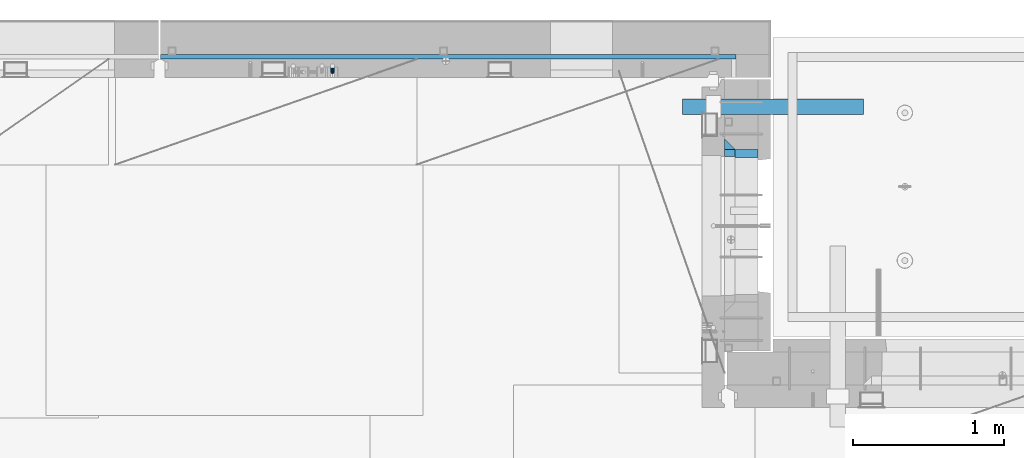
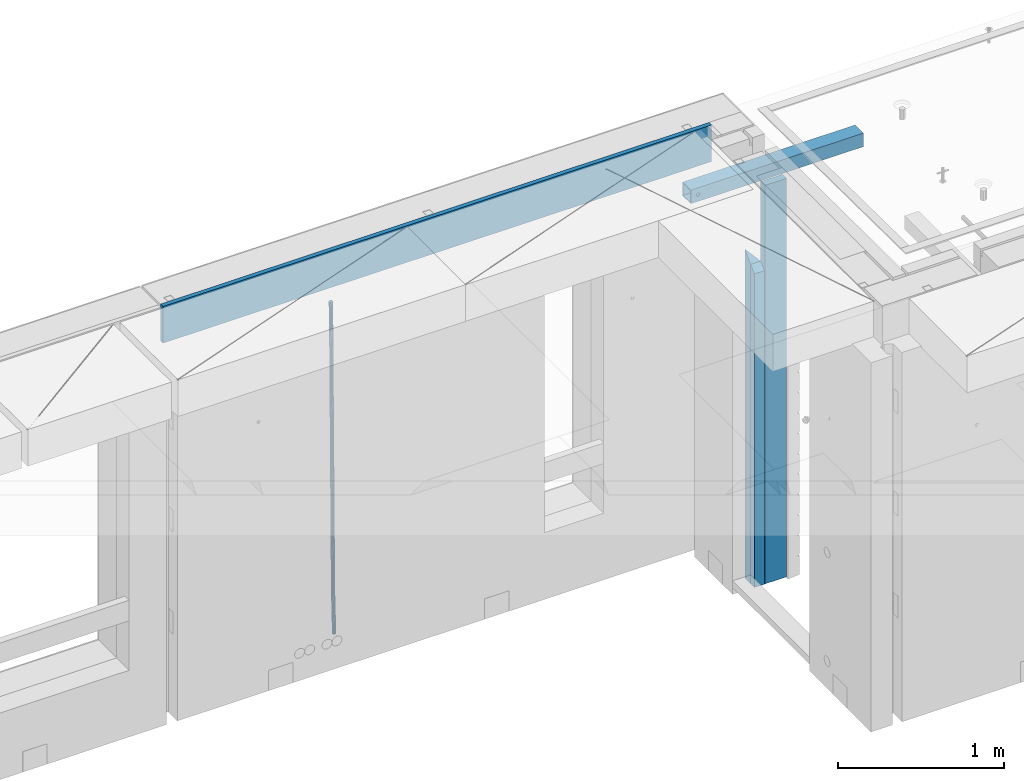
# One storey, part 122 of 334: 6 beams, 4 elements without a shape of their own.
"""IFC2X3 building model written with IfcOpenShell, lengths in millimetres."""

from ifc_helpers import new_model, si_unit, frame, origin_with_axes, place, context, subcontext, project, spatial, faceted_brep, material, type_object, element, aggregate, save


model = new_model("IFC2X3")

# Units and contexts
model_context = context("Model", 3, precision=1e-05, world=origin_with_axes())
body_context = subcontext(model_context, "Body", "Model", "MODEL_VIEW")
ifc_project = project(units=[si_unit("LENGTHUNIT", "METRE", prefix="MILLI"), si_unit("AREAUNIT", "SQUARE_METRE"), si_unit("VOLUMEUNIT", "CUBIC_METRE"), si_unit("MASSUNIT", "GRAM", prefix="KILO"), si_unit("TIMEUNIT", "SECOND"), si_unit("PLANEANGLEUNIT", "RADIAN"), si_unit("SOLIDANGLEUNIT", "STERADIAN"), si_unit("THERMODYNAMICTEMPERATUREUNIT", "DEGREE_CELSIUS"), si_unit("LUMINOUSINTENSITYUNIT", "LUMEN")], contexts=[model_context])

# Site, building, storey
site_placement = place(None, origin_with_axes())
site = spatial("IfcSite", under=ifc_project, at=site_placement, CompositionType="ELEMENT")
building_placement = place(site_placement, origin_with_axes())
building = spatial("IfcBuilding", under=site, at=building_placement, CompositionType="ELEMENT")
storey_placement = place(building_placement, origin_with_axes())
storey = spatial("IfcBuildingStorey", under=building, at=storey_placement, Name="3", CompositionType="ELEMENT", Elevation=0.0)

# Assembly, beams
assembly_1_placement = place(storey_placement, origin_with_axes())
assembly_1 = element("IfcElementAssembly", 1, at=assembly_1_placement, inside=storey, AssemblyPlace="NOTDEFINED", PredefinedType="REINFORCEMENT_UNIT")
ifc_material_1 = material(Name="CONCRETE/C25/30")
beam_type_1 = type_object("IfcBeamType", PredefinedType="NOTDEFINED")
beam_1_placement = place(assembly_1_placement, frame((31494.9951872276, 22174.9998901814, 90175.0), z_axis=(0.0, -1.0, 0.0), x_axis=(0.0, 0.0, -1.0)))
beam_1 = element("IfcBeam", 2, at=beam_1_placement, type_object=beam_type_1, material=ifc_material_1, Name="SK", context=body_context, shape_type="Brep", body=[
    faceted_brep([(2420.0, -35.0, 35.0), (2420.0, -35.0, -35.0), (2420.0, 35.0, 35.0), (70.0000000000164, 35.0, 35.0), (70.0000000000164, -35.0, 35.0), (0.0, -35.0, -35.0)], [[[0, 1, 2]], [[0, 2, 3, 4]], [[1, 0, 4, 5]], [[2, 1, 5, 3]], [[4, 3, 5]]]),
])
beam_type_2 = type_object("IfcBeamType", PredefinedType="NOTDEFINED")
beam_2_placement = place(assembly_1_placement, frame((31494.9951872276, 22114.9998901814, 90105.0), z_axis=(0.0, -1.0, 0.0), x_axis=(0.0, 0.0, -1.0)))
beam_2 = element("IfcBeam", 3, at=beam_2_placement, type_object=beam_type_2, material=ifc_material_1, Name="SK", context=body_context, shape_type="Brep", body=[
    faceted_brep([(2350.0, -35.0, -25.0), (2350.0, 35.0, -25.0), (2350.0, 35.0, 20.6410256410309), (2350.0, -35.0, 18.8461538461561), (0.0, 35.0, -25.0), (45.6410256410309, 35.0, 20.6410256410254), (43.8461538461561, -35.0, 18.8461538461543), (0.0, -35.0, -25.0)], [[[0, 1, 2, 3]], [[2, 1, 4, 5]], [[3, 2, 5, 6]], [[0, 3, 6, 7]], [[1, 0, 7, 4]], [[5, 4, 7, 6]]]),
])
ifc_material_2 = material(Name="TIMBER")
beam_type_3 = type_object("IfcBeamType", Name="50X150", PredefinedType="NOTDEFINED")
beam_3_placement = place(assembly_1_placement, frame((31604.9951872276, 22114.9998901814, 90690.0), z_axis=(0.0, -1.0, 0.0), x_axis=(0.0, 0.0, -1.0)))
beam_3 = element("IfcBeam", 4, at=beam_3_placement, type_object=beam_type_3, material=ifc_material_2, ObjectType="50X150", context=body_context, shape_type="Brep", body=[
    faceted_brep([(0.0, 75.0, -25.0), (1.81898940354586e-12, 75.0, 25.0), (2930.0, 75.0, 25.0), (2930.0, 75.0, -25.0), (1.81898940354586e-12, -75.0000000000009, 25.0), (2930.0, -75.0, 25.0), (0.0, -75.0, -25.0), (2930.0, -75.0, -25.0)], [[[0, 1, 2, 3]], [[1, 4, 5, 2]], [[4, 6, 7, 5]], [[6, 0, 3, 7]], [[5, 7, 3, 2]], [[6, 4, 1, 0]]]),
])
aggregate(assembly_1, [beam_1, beam_2, beam_3])

# Assembly, beam
assembly_2_placement = place(storey_placement, origin_with_axes())
assembly_2 = element("IfcElementAssembly", 5, at=assembly_2_placement, inside=storey, AssemblyPlace="NOTDEFINED", PredefinedType="REINFORCEMENT_UNIT")
ifc_material_3 = material()
beam_type_4 = type_object("IfcBeamType", Name="D25", PredefinedType="NOTDEFINED")
beam_4_placement = place(assembly_2_placement, frame((28860.0000000039, 22654.9999977209, 87990.0), z_axis=(-0.000205762999925498, 0.999642804629538, -0.0267249099901004), x_axis=(4.30000201928125e-08, 0.0267249099948059, 0.999642825806181)))
beam_4 = element("IfcBeam", 6, at=beam_4_placement, type_object=beam_type_4, material=ifc_material_3, Name="JM25", ObjectType="D25", context=body_context, shape_type="Brep", body=[
    faceted_brep([(-7.41420080885291e-08, -12.5, -3.63797880709171e-12), (-6.42030499875546e-08, -10.8253175473074, -6.25000000000364), (60.4103898235917, -10.8253175318459, -6.2499999938409), (60.4103898269532, -12.4999999845422, 6.16273609921336e-09), (-3.70782800018787e-08, -6.25000000000364, -10.8253175473074), (60.4103898202884, -6.24999998454587, -10.8253175411446), (-1.45519152283669e-11, -3.63797880709171e-12, -12.5), (60.4103898179019, 1.54577719513327e-08, -12.4999999938373), (3.70637280866504e-08, 6.25, -10.8253175473074), (60.410389817087, 6.25000001545777, -10.825317541141), (6.42030499875546e-08, 10.8253175473001, -6.25000000000364), (60.410389818062, 10.8253175627578, -6.24999999383726), (7.41420080885291e-08, 12.4999999999927, 0.0), (60.4103898205503, 12.5000000154541, 6.16273609921336e-09), (6.42176019027829e-08, 10.8253175473001, 6.24999999999636), (60.4103898238973, 10.8253175627651, 6.2500000061591), (3.70928319171071e-08, 6.24999999999636, 10.8253175473037), (60.4103898272151, 6.25000001546141, 10.8253175534664), (1.45519152283669e-11, -3.63797880709171e-12, 12.4999999999964), (60.4103898296162, 1.54541339725256e-08, 12.5000000061591), (-3.7049176171422e-08, -6.25000000000364, 10.8253175473001), (60.4103898304165, -6.24999998454587, 10.8253175534701), (-6.41884980723262e-08, -10.8253175473074, 6.25), (60.4103898294561, -10.8253175318459, 6.25000000616637), (61.0324985728803, -10.8253175316895, -6.24999999377542), (60.991802792938, -12.4999999843931, 6.22458173893392e-09), (61.0622854283865, -6.24999998437852, -10.8253175410755), (61.0731819955545, 1.5628756955266e-08, -12.4999999937718), (61.0622685480339, 6.25000001562512, -10.8253175410791), (61.032469335245, 10.8253175629216, -6.24999999377178), (60.9917690322181, 12.5000000156033, 6.22458173893392e-09), (60.9510732522613, 10.8253175629034, 6.25000000621731), (60.9212863967696, 6.25000001558874, 10.8253175535247), (60.9103898296162, 1.55814632307738e-08, 12.5000000062137), (60.9213032771368, -6.24999998441126, 10.8253175535174), (60.9511024898966, -10.8253175317113, 6.25000000621731), (61.6545545670233, -10.8253158516927, -6.24189838219536), (61.573166454793, -12.499998414296, 0.00757164385504439), (61.7141257553885, -6.24999822394238, -10.8168280205282), (61.7359179680789, 1.80548886419274e-06, -12.491368569139), (61.7140919992817, 6.25000177601396, -10.8168282403167), (61.6544960997562, 10.8253192428383, -6.2418987628771), (61.5730989426083, 12.5000015856094, 0.0075712042817031), (61.4917108303925, 10.8253190230062, 6.25704123032847), (61.4321396420273, 6.25000139525582, 10.8319708686649), (61.4103474293224, 1.36582457344048e-06, 12.5065114172721), (61.4321733981196, -6.24999860470052, 10.8319710884571), (61.4917692976451, -10.8253160715249, 6.25704161101385), (176.524302641745, -10.8250056210964, -4.74584321979273), (176.442914529529, -12.4996881836996, 1.50362680625403), (176.583873830095, -6.24968799334965, -9.3207728581292), (176.605666042786, 0.000312036081595579, -10.9953134067364), (176.583840074018, 6.25031200660669, -9.32077307791769), (176.524244174492, 10.8256294734347, -4.74584360047811), (176.44284701733, 12.5003118162058, 1.50362636668069), (176.361458905099, 10.8256292535989, 7.75309639272746), (176.301887716749, 6.25031162585219, 12.3280260310676), (176.280095504058, 0.000311596420942806, 14.0025665796711), (176.301921472827, -6.24968837410415, 12.3280262508561), (176.361517372367, -10.8250058409321, 7.75309677341284), (177.085397012124, -10.8250041057399, -4.73853556792164), (176.983633547483, -12.4996867233749, 1.51066909103247), (177.159881729676, -6.24968643771717, -9.31327097355097), (177.187129580227, 0.000313606451527448, -10.987740468332), (177.159839524218, 6.25031356221734, -9.31327130338468), (177.085323910098, 10.8256309887511, -4.73853613920801), (176.983549136537, 12.5003132764905, 1.51066843136869), (176.881785671867, 10.8256306588555, 7.7598730903228), (176.80730095433, 6.25031299082912, 12.3346084959521), (176.780053103794, 0.000312946667690994, 14.0090779907332), (176.807343159802, -6.2496870091054, 12.3346088257895), (176.881858773908, -10.8250044356355, 7.7598736616128), (177.646431799818, -10.8250018318176, -4.72756919822132), (177.524295146417, -12.4996845320202, 1.52123723245313), (177.735828462886, -6.24968410334986, -9.30201312475765), (177.768531371941, 0.00031596292683389, -10.9763759912421), (177.735777808921, 6.25031589654827, -9.30201361973741), (177.646344064575, 10.8256332626152, -4.72757005553649), (177.524193838486, 12.5003154677688, 1.52123624250817), (177.402057185071, 10.8256327675663, 7.77004267317898), (177.312660521988, 6.2503150390985, 12.3444865997226), (177.279957612933, 0.00031497282179771, 14.0188494661961), (177.312711175953, -6.24968496079964, 12.3444870946951), (177.402144920314, -10.8250023268702, 7.77004353049415), (299.377443161706, -10.8245084454466, -2.34813158632096), (299.255306508276, -12.4991911456491, 3.90067484435349), (299.466839824803, -6.24919071697514, -6.92257551286093), (299.499542733873, 0.0008093492979242, -8.59693837933446), (299.466789170867, 6.250809282923, -6.92257600783341), (299.377355426492, 10.8261266489935, -2.34813244364341), (299.255205200388, 12.5008088541435, 3.90067385440125), (299.133068546944, 10.826126153941, 10.1494802850757), (299.043671883861, 6.25080842546959, 14.7239242116229), (299.010968974762, 0.000808359200163977, 16.3982870780892), (299.043722537797, -6.24919157442127, 14.7239247065918), (299.133156282158, -10.8245089404954, 10.1494811423981), (299.98561436501, -10.8245059804758, -2.33624385599614), (299.97179243555, -12.4991882411778, 3.91467976726199), (299.995742293278, -6.24918857328521, -6.91223722345239), (299.999447243041, 0.000811375455668895, -8.58716690387519), (299.995736475976, 6.25081142679483, -6.91223684201032), (299.985604289133, 10.8261291142808, -2.33624319533556), (299.971750386685, 12.5008117588586, 3.91467993563856), (299.957928457196, 10.8261294971744, 10.1656035610831), (299.947800528913, 6.25081208998381, 14.7415969285394), (299.944095579151, 0.00081214124293183, 16.4165266089549), (299.947806346216, -6.24918791008895, 14.7415965471009), (299.957938533058, -10.8245055975785, 10.1656029004225), (300.593832239858, -10.8245078794353, -2.34543881707941), (300.688302931099, -12.4991904788549, 3.90384712594823), (300.524685350189, -6.24919022474205, -6.92023371784308), (300.499390115292, 0.000809814544481924, -8.59472497713432), (300.524724372954, 6.25080977519247, -6.92023401429469), (300.593899829313, 10.8261272150703, -2.34543933054374), (300.688380976673, 12.5008095210287, 3.90384653304136), (300.782851667915, 10.8261269216127, 10.1531324760799), (300.851998557599, 6.25080926691589, 14.7279273768363), (300.877293792495, 0.000809227632998955, 16.4024186361276), (300.851959534804, -6.24919073302226, 14.7279276732806), (300.782784078474, -10.8245081728965, 10.153132989537), (2293.32930409742, -10.8307295605009, -32.4713622331001), (2293.42377478865, -12.5054121599169, -26.2220762900724), (2293.26015720774, -6.2554119058077, -37.0461571338565), (2293.23486197284, -0.00541186651753378, -38.7206483931477), (2293.26019623051, 6.24458809413409, -37.0461574303008), (2293.32937168686, 10.8199055340046, -32.4713627465644), (2293.42385283421, 12.4945878399631, -26.2220768829684), (2293.51832352545, 10.8199052405434, -19.972790939948), (2293.58747041514, 6.24458758585388, -15.3979960391844), (2293.61276565003, -0.00541245343265473, -13.7235047798931), (2293.58743139236, -6.25541241408428, -15.3979957427327), (2293.51825593603, -10.8307298539585, -19.9727904264691), (2294.0420846676, -10.8307317859326, -32.4821379598216), (2294.03681932652, -12.5054140739521, -26.2313442200393), (2294.06778164886, -6.2554144273563, -37.0583666982457), (2294.10702478497, -0.00541458957013674, -38.7338336404937), (2294.14929890928, 6.24458531819619, -37.0595987724118), (2294.18327670435, 10.8199028679592, -32.4842719748667), (2294.1998538474, 12.4945854171456, -26.2338083683717), (2294.19458850632, 10.819903129126, -19.9830146285858), (2294.16889152506, 6.24458577054975, -15.4067858901581), (2294.12964838895, -0.0054140672327776, -13.7313189479173), (2294.08737426462, -6.2554139749991, -15.4055538159919), (2294.05339646956, -10.8307315247621, -19.9808806135297), (2294.75482297382, -10.84002603931, -32.4726521173216), (2294.64982751427, -12.513407826169, -26.2231856868602), (2294.87535820232, -6.26594539088183, -37.0476186524102), (2294.97913588268, -0.0167870967634371, -38.7222267036377), (2295.0383488692, 6.23299192477134, -37.0477663960555), (2295.03713108998, 10.8087684320271, -32.4729080168181), (2294.97580884799, 12.4844668051373, -26.2234811741473), (2294.87081338844, 10.8110850182784, -19.9740147436787), (2294.7502781599, 6.23700436985018, -15.3990482086047), (2294.64650047956, -0.0121539242718427, -13.7244401573698), (2294.58728749304, -6.26193294580662, -15.3989004649666), (2294.58850527227, -10.8377094530588, -19.9737588441894), (2316.44667268227, -11.1228921988077, -32.1839550346631), (2316.34167722271, -12.7962739856739, -25.9344886042054), (2316.56720791078, -6.54881155039038, -36.7589215697517), (2316.67098559113, -0.299653256264719, -38.4335296209792), (2316.73019857766, 5.95012576527006, -36.759069313397), (2316.72898079845, 10.5259022725259, -32.1842109341669), (2316.66765855643, 12.2016006456361, -25.9347840914961), (2316.56266309689, 10.5282188587698, -19.6853176610275), (2316.44212786836, 5.95413821035254, -15.1103511259389), (2316.33835018802, -0.295020083769487, -13.4357430747186), (2316.27913720149, -6.54479910530426, -15.1102033823008), (2316.28035498071, -11.1205756125637, -19.685061761531), (2317.13234804722, -11.1318335458927, -32.1748293731798), (2317.04181141085, -12.8054038787741, -25.9251705100723), (2317.2154741603, -6.5572650749491, -36.7502937866229), (2317.26891617525, -0.307450393454928, -38.4255717558117), (2317.27835434731, 5.94297770185585, -36.7517739018112), (2317.24125972588, 10.5192220504723, -32.1773930078925), (2317.16757178486, 12.1950816748285, -25.9281307404563), (2317.0770351485, 10.5215113419545, -19.6784718773561), (2316.99390903539, 5.94694287101083, -15.1030074639057), (2316.94046702047, -0.302871810494253, -13.4277294947169), (2316.9310288484, -6.55329990579412, -15.1015273487101), (2316.96812346982, -11.1295442544142, -19.6759082426288), (2317.81808136747, -11.1298054502913, -32.1659056455355), (2317.74200467508, -12.803315894289, -25.9160547315114), (2317.86379538118, -6.55536082026447, -36.7418676070083), (2317.8668976831, -0.305700748642266, -38.417815303761), (2317.82655701396, 5.94458339541234, -36.7446799039099), (2317.75358262347, 10.5207330230332, -32.1707766866384), (2317.66752794063, 12.1965725370646, -25.9216793252963), (2317.59145124823, 10.5230620930706, -19.6718284112721), (2317.54573723453, 5.94861746304377, -15.0958664497994), (2317.54263493262, -0.301042608574789, -13.4199187530394), (2317.58297560175, -6.55132675263303, -15.0930541529051), (2317.65594999224, -11.1274763802539, -19.6669573701693), (2417.81884292323, -10.831603083323, -30.8687911350135), (2417.74276623082, -12.505113527317, -24.618940220982), (2417.86455693691, -6.25715845329614, -35.4447530964935), (2417.86765923884, -0.00749838167394046, -37.1207007932499), (2417.82731856969, 6.24278576237703, -35.4475653933878), (2417.75434417921, 10.8189353900088, -30.8736621761236), (2417.66828949639, 12.494774904033, -24.6245648147851), (2417.59221280397, 10.8212644600353, -18.3747139007501), (2417.54649879028, 6.2468198300121, -13.79875193927), (2417.54339648837, -0.00284024161010166, -12.1228042425173), (2417.5837371575, -6.25312438566107, -13.795939642383), (2417.65671154798, -10.8292740132893, -18.3698428596399)], [[[0, 1, 2, 3]], [[1, 4, 5, 2]], [[4, 6, 7, 5]], [[6, 8, 9, 7]], [[8, 10, 11, 9]], [[10, 12, 13, 11]], [[12, 14, 15, 13]], [[14, 16, 17, 15]], [[16, 18, 19, 17]], [[18, 20, 21, 19]], [[20, 22, 23, 21]], [[22, 0, 3, 23]], [[22, 20, 18, 16, 14, 12, 10, 8, 6, 4, 1, 0]], [[3, 2, 24, 25]], [[2, 5, 26, 24]], [[5, 7, 27, 26]], [[7, 9, 28, 27]], [[9, 11, 29, 28]], [[11, 13, 30, 29]], [[13, 15, 31, 30]], [[15, 17, 32, 31]], [[17, 19, 33, 32]], [[19, 21, 34, 33]], [[21, 23, 35, 34]], [[23, 3, 25, 35]], [[25, 24, 36, 37]], [[24, 26, 38, 36]], [[26, 27, 39, 38]], [[27, 28, 40, 39]], [[28, 29, 41, 40]], [[29, 30, 42, 41]], [[30, 31, 43, 42]], [[31, 32, 44, 43]], [[32, 33, 45, 44]], [[33, 34, 46, 45]], [[34, 35, 47, 46]], [[35, 25, 37, 47]], [[37, 36, 48, 49]], [[36, 38, 50, 48]], [[38, 39, 51, 50]], [[39, 40, 52, 51]], [[40, 41, 53, 52]], [[41, 42, 54, 53]], [[42, 43, 55, 54]], [[43, 44, 56, 55]], [[44, 45, 57, 56]], [[45, 46, 58, 57]], [[46, 47, 59, 58]], [[47, 37, 49, 59]], [[49, 48, 60, 61]], [[48, 50, 62, 60]], [[50, 51, 63, 62]], [[51, 52, 64, 63]], [[52, 53, 65, 64]], [[53, 54, 66, 65]], [[54, 55, 67, 66]], [[55, 56, 68, 67]], [[56, 57, 69, 68]], [[57, 58, 70, 69]], [[58, 59, 71, 70]], [[59, 49, 61, 71]], [[61, 60, 72, 73]], [[60, 62, 74, 72]], [[62, 63, 75, 74]], [[63, 64, 76, 75]], [[64, 65, 77, 76]], [[65, 66, 78, 77]], [[66, 67, 79, 78]], [[67, 68, 80, 79]], [[68, 69, 81, 80]], [[69, 70, 82, 81]], [[70, 71, 83, 82]], [[71, 61, 73, 83]], [[73, 72, 84, 85]], [[72, 74, 86, 84]], [[74, 75, 87, 86]], [[75, 76, 88, 87]], [[76, 77, 89, 88]], [[77, 78, 90, 89]], [[78, 79, 91, 90]], [[79, 80, 92, 91]], [[80, 81, 93, 92]], [[81, 82, 94, 93]], [[82, 83, 95, 94]], [[83, 73, 85, 95]], [[85, 84, 96, 97]], [[84, 86, 98, 96]], [[86, 87, 99, 98]], [[87, 88, 100, 99]], [[88, 89, 101, 100]], [[89, 90, 102, 101]], [[90, 91, 103, 102]], [[91, 92, 104, 103]], [[92, 93, 105, 104]], [[93, 94, 106, 105]], [[94, 95, 107, 106]], [[95, 85, 97, 107]], [[97, 96, 108, 109]], [[96, 98, 110, 108]], [[98, 99, 111, 110]], [[99, 100, 112, 111]], [[100, 101, 113, 112]], [[101, 102, 114, 113]], [[102, 103, 115, 114]], [[103, 104, 116, 115]], [[104, 105, 117, 116]], [[105, 106, 118, 117]], [[106, 107, 119, 118]], [[107, 97, 109, 119]], [[109, 108, 120, 121]], [[108, 110, 122, 120]], [[110, 111, 123, 122]], [[111, 112, 124, 123]], [[112, 113, 125, 124]], [[113, 114, 126, 125]], [[114, 115, 127, 126]], [[115, 116, 128, 127]], [[116, 117, 129, 128]], [[117, 118, 130, 129]], [[118, 119, 131, 130]], [[119, 109, 121, 131]], [[121, 120, 132, 133]], [[120, 122, 134, 132]], [[122, 123, 135, 134]], [[123, 124, 136, 135]], [[124, 125, 137, 136]], [[125, 126, 138, 137]], [[126, 127, 139, 138]], [[127, 128, 140, 139]], [[128, 129, 141, 140]], [[129, 130, 142, 141]], [[130, 131, 143, 142]], [[131, 121, 133, 143]], [[133, 132, 144, 145]], [[132, 134, 146, 144]], [[134, 135, 147, 146]], [[135, 136, 148, 147]], [[136, 137, 149, 148]], [[137, 138, 150, 149]], [[138, 139, 151, 150]], [[139, 140, 152, 151]], [[140, 141, 153, 152]], [[141, 142, 154, 153]], [[142, 143, 155, 154]], [[143, 133, 145, 155]], [[145, 144, 156, 157]], [[144, 146, 158, 156]], [[146, 147, 159, 158]], [[147, 148, 160, 159]], [[148, 149, 161, 160]], [[149, 150, 162, 161]], [[150, 151, 163, 162]], [[151, 152, 164, 163]], [[152, 153, 165, 164]], [[153, 154, 166, 165]], [[154, 155, 167, 166]], [[155, 145, 157, 167]], [[157, 156, 168, 169]], [[156, 158, 170, 168]], [[158, 159, 171, 170]], [[159, 160, 172, 171]], [[160, 161, 173, 172]], [[161, 162, 174, 173]], [[162, 163, 175, 174]], [[163, 164, 176, 175]], [[164, 165, 177, 176]], [[165, 166, 178, 177]], [[166, 167, 179, 178]], [[167, 157, 169, 179]], [[169, 168, 180, 181]], [[168, 170, 182, 180]], [[170, 171, 183, 182]], [[171, 172, 184, 183]], [[172, 173, 185, 184]], [[173, 174, 186, 185]], [[174, 175, 187, 186]], [[175, 176, 188, 187]], [[176, 177, 189, 188]], [[177, 178, 190, 189]], [[178, 179, 191, 190]], [[179, 169, 181, 191]], [[181, 180, 192, 193]], [[180, 182, 194, 192]], [[182, 183, 195, 194]], [[183, 184, 196, 195]], [[184, 185, 197, 196]], [[185, 186, 198, 197]], [[186, 187, 199, 198]], [[187, 188, 200, 199]], [[188, 189, 201, 200]], [[189, 190, 202, 201]], [[190, 191, 203, 202]], [[191, 181, 193, 203]], [[194, 195, 196, 197, 198, 199, 200, 201, 202, 203, 193, 192]]]),
])

# Assemblies, beam
assembly_3_placement = place(storey_placement, origin_with_axes())
assembly_3 = element("IfcElementAssembly", 7, at=assembly_3_placement, inside=storey, AssemblyPlace="NOTDEFINED", PredefinedType="REINFORCEMENT_UNIT")
assembly_4_placement = place(assembly_3_placement, origin_with_axes())
assembly_4 = element("IfcElementAssembly", 8, at=assembly_4_placement, AssemblyPlace="NOTDEFINED", PredefinedType="NOTDEFINED")
aggregate(assembly_3, [assembly_4])
ifc_material_4 = material(Name="Undefined/350")
beam_type_5 = type_object("IfcBeamType", Name="100X100X5", PredefinedType="NOTDEFINED")
beam_5_placement = place(assembly_4_placement, frame((32380.0034426031, 22424.9998567989, 90555.0), z_axis=(0.0, 0.0, 1.0), x_axis=(-0.999999999752625, 2.22429999942101e-05, 0.0)))
beam_5 = element("IfcBeam", 9, at=beam_5_placement, type_object=beam_type_5, material=ifc_material_4, ObjectType="100X100X5", context=body_context, shape_type="Brep", body=[
    faceted_brep([(1139.17579440585, -49.9744051074349, 6.25), (1139.1757927444, -44.9999999999991, 6.25), (1143.75111029171, -44.9999999999991, 10.8253175473074), (1143.75111195316, -49.9744035792783, 10.8253175473074), (1150.00111029171, -44.9999999999991, 12.5), (1150.00111195316, -49.9744014917787, 12.5), (1156.25111029171, -44.9999999999991, 10.8253175473074), (1156.25111195316, -49.9743994042774, 10.8253175473074), (1160.82642783901, -44.9999999999991, 6.25), (1160.82642950046, -49.9743978761207, 6.25), (1162.50111029171, -44.9999999999991, 0.0), (1162.50111195316, -49.9743973167779, 0.0), (1160.82642783901, -44.9999999999991, -6.25), (1160.82642950046, -49.9743978761207, -6.25), (1156.25111029171, -44.9999999999991, -10.8253175473074), (1156.25111195316, -49.9743994042774, -10.8253175473074), (1150.00111029171, -44.9999999999991, -12.5), (1150.00111195316, -49.9744014917787, -12.5), (1143.75111029171, -44.9999999999991, -10.8253175473074), (1143.75111195316, -49.9744035792783, -10.8253175473074), (1139.1757927444, -44.9999999999991, -6.25), (1139.17579440585, -49.9744051074349, -6.25), (1137.50111029171, -44.9999999999991, 0.0), (1137.50111195316, -49.9744056667778, 0.0), (1139.1757626844, 44.9999999999982, 6.25), (1139.17576100585, 50.0255948914664, 6.25), (1143.75107855316, 50.0255964196231, 10.8253175473074), (1143.75108023171, 44.9999999999982, 10.8253175473074), (1150.00107855316, 50.0255985071226, 12.5), (1150.00108023171, 44.9999999999982, 12.5), (1156.25107855315, 50.0256005946221, 10.8253175473074), (1156.2510802317, 44.9999999999982, 10.8253175473074), (1160.82639610046, 50.0256021227788, 6.25), (1160.82639777901, 44.9999999999982, 6.25), (1162.50107855316, 50.0256026821226, 0.0), (1162.50108023171, 44.9999999999982, 0.0), (1160.82639610046, 50.0256021227788, -6.25), (1160.82639777901, 44.9999999999982, -6.25), (1156.25107855315, 50.0256005946221, -10.8253175473074), (1156.2510802317, 44.9999999999982, -10.8253175473074), (1150.00107855316, 50.0255985071226, -12.5), (1150.00108023171, 44.9999999999982, -12.5), (1143.75107855316, 50.0255964196231, -10.8253175473074), (1143.75108023171, 44.9999999999982, -10.8253175473074), (1139.17576100585, 50.0255948914664, -6.25), (1139.1757626844, 44.9999999999982, -6.25), (1137.50107855316, 50.0255943321226, 0.0), (1137.5010802317, 44.9999999999982, 0.0), (1.81898940354586e-12, -50.0000000000009, -50.0), (1.81898940354586e-12, 49.9999999999991, -50.0), (1200.00449189278, 49.9999999999982, -50.0), (1200.00449189278, -50.0000000000009, -50.0), (1.81898940354586e-12, -50.0000000000009, 50.0), (1200.00449189278, -50.0000000000009, 50.0), (1.81898940354586e-12, 49.9999999999991, 50.0), (1200.00449189278, 49.9999999999982, 50.0), (0.0, 44.9999999999991, 45.0), (1.81898940354586e-12, -45.0000000000009, 45.0), (1.81898940354586e-12, -45.0000000000009, -45.0), (0.0, 44.9999999999991, -45.0), (1200.00449189278, 44.9999999999982, -45.0), (1200.00449189278, 44.9999999999982, 45.0), (1200.00449189278, -45.0000000000009, 45.0), (1200.00449189278, -45.0000000000009, -45.0)], [[[0, 1, 2, 3]], [[3, 2, 4, 5]], [[5, 4, 6, 7]], [[7, 6, 8, 9]], [[9, 8, 10, 11]], [[11, 10, 12, 13]], [[13, 12, 14, 15]], [[15, 14, 16, 17]], [[17, 16, 18, 19]], [[19, 18, 20, 21]], [[21, 20, 22, 23]], [[23, 22, 1, 0]], [[24, 25, 26, 27]], [[27, 26, 28, 29]], [[29, 28, 30, 31]], [[31, 30, 32, 33]], [[33, 32, 34, 35]], [[35, 34, 36, 37]], [[37, 36, 38, 39]], [[39, 38, 40, 41]], [[41, 40, 42, 43]], [[43, 42, 44, 45]], [[45, 44, 46, 47]], [[47, 46, 25, 24]], [[48, 49, 50, 51]], [[52, 48, 51, 53], [15, 17, 19, 21, 23, 0, 3, 5, 7, 9, 11, 13]], [[54, 52, 53, 55]], [[48, 52, 54, 49], [56, 57, 58, 59]], [[56, 59, 60, 61], [39, 41, 43, 45, 47, 24, 27, 29, 31, 33, 35, 37]], [[57, 56, 61, 62]], [[58, 57, 62, 63], [6, 4, 2, 1, 22, 20, 18, 16, 14, 12, 10, 8]], [[59, 58, 63, 60]], [[53, 51, 50, 55], [62, 61, 60, 63]], [[49, 54, 55, 50], [30, 28, 26, 25, 46, 44, 42, 40, 38, 36, 34, 32]]]),
])
aggregate(assembly_4, [beam_5])

# Beam
beam_type_6 = type_object("IfcBeamType", Name="270X30", PredefinedType="NOTDEFINED")
beam_6_placement = place(assembly_2_placement, frame((31535.0, 22755.0, 90605.0), z_axis=(0.0, 0.0, 1.0), x_axis=(-1.0, 3.00000001838171e-08, 0.0)))
beam_6 = element("IfcBeam", 10, at=beam_6_placement, type_object=beam_type_6, material=ifc_material_1, ObjectType="270X30", context=body_context, shape_type="Brep", body=[
    faceted_brep([(0.0, 15.0, -135.0), (0.0, 15.0, 135.0), (3815.00000000003, 15.0, 135.0), (3815.00000000003, 15.0, -135.0), (0.0, -15.0, 135.0), (3815.00000000003, -15.0, 135.0), (0.0, -15.0, -135.0), (3815.00000000003, -15.0, -135.0)], [[[0, 1, 2, 3]], [[1, 4, 5, 2]], [[4, 6, 7, 5]], [[6, 0, 3, 7]], [[5, 7, 3, 2]], [[6, 4, 1, 0]]]),
])

aggregate(assembly_2, [beam_4, beam_6])

save(model, "model.ifc")
